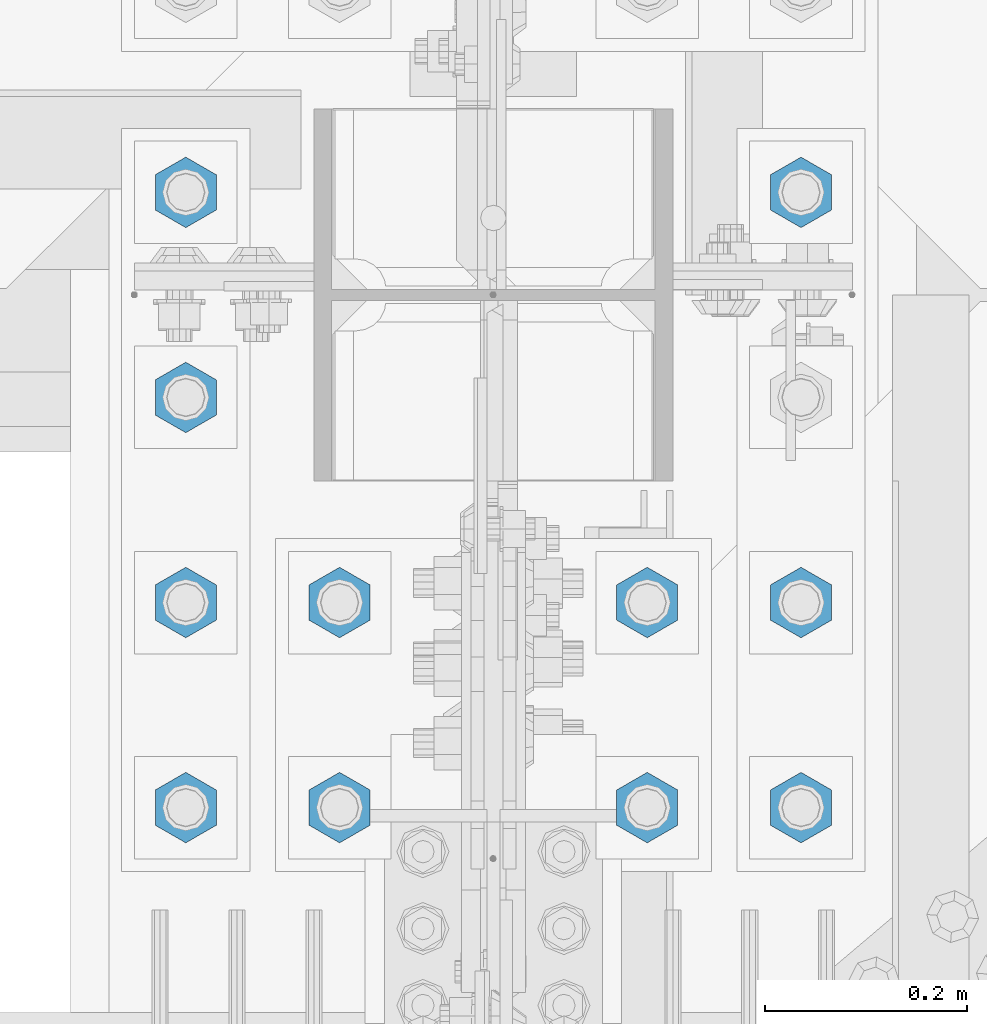
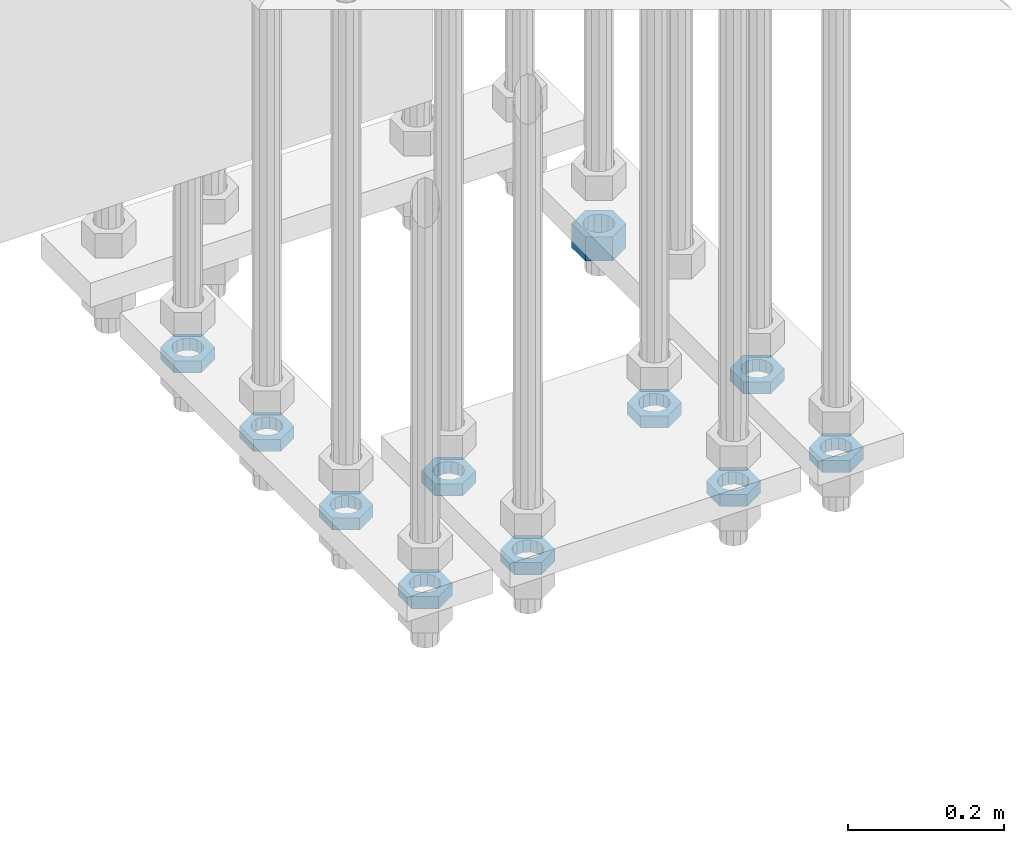
# One storey, part 2840 of 3843: 11 beams, 1 element without a shape of its own.
"""IFC2X3 building model written with IfcOpenShell, lengths in millimetres."""

from ifc_helpers import new_model, si_unit, frame, origin_with_axes, place, context, subcontext, project, spatial, faceted_brep, material, type_object, element, aggregate, save


model = new_model("IFC2X3")

# Units and contexts
model_context = context("Model", 3, precision=1e-05, world=origin_with_axes())
body_context = subcontext(model_context, "Body", "Model", "MODEL_VIEW")
ifc_project = project(units=[si_unit("LENGTHUNIT", "METRE", prefix="MILLI"), si_unit("AREAUNIT", "SQUARE_METRE"), si_unit("VOLUMEUNIT", "CUBIC_METRE"), si_unit("MASSUNIT", "GRAM", prefix="KILO"), si_unit("TIMEUNIT", "SECOND"), si_unit("PLANEANGLEUNIT", "RADIAN"), si_unit("SOLIDANGLEUNIT", "STERADIAN"), si_unit("THERMODYNAMICTEMPERATUREUNIT", "DEGREE_CELSIUS"), si_unit("LUMINOUSINTENSITYUNIT", "LUMEN")], contexts=[model_context])

# Site, building, storey
site_placement = place(None, origin_with_axes())
site = spatial("IfcSite", under=ifc_project, at=site_placement, CompositionType="ELEMENT")
building_placement = place(site_placement, origin_with_axes())
building = spatial("IfcBuilding", under=site, at=building_placement, Name="Undefined", CompositionType="ELEMENT")
storey_placement = place(building_placement, origin_with_axes())
storey = spatial("IfcBuildingStorey", under=building, at=storey_placement, Name="Undefined", CompositionType="ELEMENT", Elevation=0.0)

# Assembly, beams
assembly_placement = place(storey_placement, origin_with_axes())
assembly = element("IfcElementAssembly", 1, at=assembly_placement, inside=storey, Name="TEMPLATE", AssemblyPlace="NOTDEFINED", PredefinedType="RIGID_FRAME")
ifc_material = material(Name="STEEL/A572-50")
beam_type_1 = type_object("IfcBeamType", Name="1-1/2_HEAVY_HEX_NUT", PredefinedType="NOTDEFINED")
beam_1_placement = place(assembly_placement, frame((77317.6, 25717.5, 29203.6500015259), z_axis=(1.0, 0.0, 0.0), x_axis=(0.0, 0.0, -1.0)))
beam_1 = element("IfcBeam", 2, at=beam_1_placement, type_object=beam_type_1, material=ifc_material, Name="NUT", ObjectType="1-1/2_HEAVY_HEX_NUT", context=body_context, shape_type="Brep", body=[
    faceted_brep([(0.0, -34.9199981689453, 0.0), (0.0, -17.4599990844727, -30.25), (38.0999999999985, -17.4599990844727, -30.25), (38.0999999999985, -34.9199981689453, 0.0), (0.0, 17.4599990844727, -30.25), (38.0999999999985, 17.4599990844727, -30.25), (0.0, 34.9199981689453, 0.0), (38.0999999999985, 34.9199981689453, 0.0), (0.0, 17.4599990844727, 30.25), (38.0999999999985, 17.4599990844727, 30.25), (0.0, -17.4599990844727, 30.25), (38.0999999999985, -17.4599990844727, 30.25), (0.0, 0.0, 20.6399993896484), (0.0, 8.9553601105581, 18.5959968835959), (38.0999999999985, 8.9553601105581, 18.5959968835959), (38.0999999999985, 0.0, 20.6399993896484), (0.0, 16.1370013209525, 12.8688291298167), (38.0999999999985, 16.1370013209525, 12.8688291298167), (0.0, 20.1225115123816, 4.59283194104501), (38.0999999999985, 20.1225115123816, 4.59283194104501), (0.0, 20.1225115123816, -4.59283194104501), (38.0999999999985, 20.1225115123816, -4.59283194104501), (0.0, 16.1370013209525, -12.8688291298167), (38.0999999999985, 16.1370013209525, -12.8688291298167), (0.0, 8.9553601105581, -18.5959968835959), (38.0999999999985, 8.9553601105581, -18.5959968835959), (0.0, 0.0, -20.6399993896484), (38.0999999999985, 0.0, -20.6399993896484), (0.0, -8.9553601105581, -18.5959968835959), (38.0999999999985, -8.9553601105581, -18.5959968835959), (0.0, -16.1370013209525, -12.8688291298167), (38.0999999999985, -16.1370013209525, -12.8688291298167), (0.0, -20.1225115123816, -4.59283194104501), (38.0999999999985, -20.1225115123816, -4.59283194104501), (0.0, -20.1225115123816, 4.59283194104501), (38.0999999999985, -20.1225115123816, 4.59283194104501), (0.0, -16.1370013209525, 12.8688291298167), (38.0999999999985, -16.1370013209525, 12.8688291298167), (0.0, -8.9553601105581, 18.5959968835959), (38.0999999999985, -8.9553601105581, 18.5959968835959)], [[[0, 1, 2, 3]], [[1, 4, 5, 2]], [[4, 6, 7, 5]], [[6, 8, 9, 7]], [[8, 10, 11, 9]], [[10, 0, 3, 11]], [[12, 13, 14, 15]], [[13, 16, 17, 14]], [[16, 18, 19, 17]], [[18, 20, 21, 19]], [[20, 22, 23, 21]], [[22, 24, 25, 23]], [[24, 26, 27, 25]], [[26, 28, 29, 27]], [[28, 30, 31, 29]], [[30, 32, 33, 31]], [[32, 34, 35, 33]], [[34, 36, 37, 35]], [[36, 38, 39, 37]], [[38, 12, 15, 39]], [[5, 7, 9, 11, 3, 2], [17, 19, 21, 23, 25, 27, 29, 31, 33, 35, 37, 39, 15, 14]], [[10, 8, 6, 4, 1, 0], [38, 36, 34, 32, 30, 28, 26, 24, 22, 20, 18, 16, 13, 12]]]),
])
beam_type_2 = type_object("IfcBeamType", Name="1-1/2_HALF_NUT", PredefinedType="NOTDEFINED")
beam_2_placement = place(assembly_placement, frame((77317.6, 25311.1, 29222.7000015259), z_axis=(-1.0, 0.0, 0.0), x_axis=(0.0, 0.0, -1.0)))
beam_2 = element("IfcBeam", 3, at=beam_2_placement, type_object=beam_type_2, material=ifc_material, Name="NUT", ObjectType="1-1/2_HALF_NUT", context=body_context, shape_type="Brep", body=[
    faceted_brep([(0.0, -34.9199981689453, 0.0), (0.0, -17.4599990844727, -30.25), (19.0500000000029, -17.4599990844727, -30.25), (19.0500000000029, -34.9199981689453, 0.0), (0.0, 17.4599990844727, -30.25), (19.0500000000029, 17.4599990844727, -30.25), (0.0, 34.9199981689453, 0.0), (19.0500000000029, 34.9199981689453, 0.0), (0.0, 17.4599990844727, 30.25), (19.0500000000029, 17.4599990844727, 30.25), (0.0, -17.4599990844727, 30.25), (19.0500000000029, -17.4599990844727, 30.25), (0.0, 0.0, 20.6399993896484), (0.0, 8.9553601105581, 18.5959968835959), (19.0500000000029, 8.95536011056538, 18.5959968835959), (19.0500000000029, 0.0, 20.6399993896484), (0.0, 16.1370013209525, 12.8688291298167), (19.0500000000029, 16.1370013209489, 12.8688291298167), (0.0, 20.1225115123816, 4.59283194104501), (19.0500000000029, 20.1225115123852, 4.59283194104501), (0.0, 20.1225115123816, -4.59283194104501), (19.0500000000029, 20.1225115123852, -4.59283194104501), (0.0, 16.1370013209525, -12.8688291298167), (19.0500000000029, 16.1370013209489, -12.8688291298167), (0.0, 8.9553601105581, -18.5959968835959), (19.0500000000029, 8.95536011056538, -18.5959968835959), (0.0, 0.0, -20.6399993896484), (19.0500000000029, 0.0, -20.6399993896484), (0.0, -8.9553601105581, -18.5959968835959), (19.0500000000029, -8.95536011056538, -18.5959968835959), (0.0, -16.1370013209525, -12.8688291298167), (19.0500000000029, -16.1370013209489, -12.8688291298167), (0.0, -20.1225115123816, -4.59283194104501), (19.0500000000029, -20.1225115123852, -4.59283194104501), (0.0, -20.1225115123816, 4.59283194104501), (19.0500000000029, -20.1225115123852, 4.59283194104501), (0.0, -16.1370013209525, 12.8688291298167), (19.0500000000029, -16.1370013209489, 12.8688291298167), (0.0, -8.9553601105581, 18.5959968835959), (19.0500000000029, -8.95536011056538, 18.5959968835959)], [[[0, 1, 2, 3]], [[1, 4, 5, 2]], [[4, 6, 7, 5]], [[6, 8, 9, 7]], [[8, 10, 11, 9]], [[10, 0, 3, 11]], [[12, 13, 14, 15]], [[13, 16, 17, 14]], [[16, 18, 19, 17]], [[18, 20, 21, 19]], [[20, 22, 23, 21]], [[22, 24, 25, 23]], [[24, 26, 27, 25]], [[26, 28, 29, 27]], [[28, 30, 31, 29]], [[30, 32, 33, 31]], [[32, 34, 35, 33]], [[34, 36, 37, 35]], [[36, 38, 39, 37]], [[38, 12, 15, 39]], [[5, 7, 9, 11, 3, 2], [17, 19, 21, 23, 25, 27, 29, 31, 33, 35, 37, 39, 15, 14]], [[10, 8, 6, 4, 1, 0], [38, 36, 34, 32, 30, 28, 26, 24, 22, 20, 18, 16, 13, 12]]]),
])
beam_3_placement = place(assembly_placement, frame((77317.6, 25107.899974823, 29222.7), z_axis=(-1.0, 0.0, 0.0), x_axis=(0.0, 0.0, -1.0)))
beam_3 = element("IfcBeam", 4, at=beam_3_placement, type_object=beam_type_2, material=ifc_material, Name="NUT", ObjectType="1-1/2_HALF_NUT", context=body_context, shape_type="Brep", body=[
    faceted_brep([(0.0, -34.9199981689453, 0.0), (0.0, -17.4599990844727, -30.25), (19.0500000000029, -17.4599990844727, -30.25), (19.0500000000029, -34.9199981689453, 0.0), (0.0, 17.4599990844727, -30.25), (19.0500000000029, 17.4599990844727, -30.25), (0.0, 34.9199981689453, 0.0), (19.0500000000029, 34.9199981689453, 0.0), (0.0, 17.4599990844727, 30.25), (19.0500000000029, 17.4599990844727, 30.25), (0.0, -17.4599990844727, 30.25), (19.0500000000029, -17.4599990844727, 30.25), (0.0, 0.0, 20.6399993896484), (0.0, 8.9553601105581, 18.5959968835959), (19.0500000000029, 8.95536011056538, 18.5959968835959), (19.0500000000029, 0.0, 20.6399993896484), (0.0, 16.1370013209525, 12.8688291298167), (19.0500000000029, 16.1370013209489, 12.8688291298167), (0.0, 20.1225115123816, 4.59283194104501), (19.0500000000029, 20.1225115123852, 4.59283194104501), (0.0, 20.1225115123816, -4.59283194104501), (19.0500000000029, 20.1225115123852, -4.59283194104501), (0.0, 16.1370013209525, -12.8688291298167), (19.0500000000029, 16.1370013209489, -12.8688291298167), (0.0, 8.9553601105581, -18.5959968835959), (19.0500000000029, 8.95536011056538, -18.5959968835959), (0.0, 0.0, -20.6399993896484), (19.0500000000029, 0.0, -20.6399993896484), (0.0, -8.9553601105581, -18.5959968835959), (19.0500000000029, -8.95536011056538, -18.5959968835959), (0.0, -16.1370013209525, -12.8688291298167), (19.0500000000029, -16.1370013209489, -12.8688291298167), (0.0, -20.1225115123816, -4.59283194104501), (19.0500000000029, -20.1225115123852, -4.59283194104501), (0.0, -20.1225115123816, 4.59283194104501), (19.0500000000029, -20.1225115123852, 4.59283194104501), (0.0, -16.1370013209525, 12.8688291298167), (19.0500000000029, -16.1370013209489, 12.8688291298167), (0.0, -8.9553601105581, 18.5959968835959), (19.0500000000029, -8.95536011056538, 18.5959968835959)], [[[0, 1, 2, 3]], [[1, 4, 5, 2]], [[4, 6, 7, 5]], [[6, 8, 9, 7]], [[8, 10, 11, 9]], [[10, 0, 3, 11]], [[12, 13, 14, 15]], [[13, 16, 17, 14]], [[16, 18, 19, 17]], [[18, 20, 21, 19]], [[20, 22, 23, 21]], [[22, 24, 25, 23]], [[24, 26, 27, 25]], [[26, 28, 29, 27]], [[28, 30, 31, 29]], [[30, 32, 33, 31]], [[32, 34, 35, 33]], [[34, 36, 37, 35]], [[36, 38, 39, 37]], [[38, 12, 15, 39]], [[5, 7, 9, 11, 3, 2], [17, 19, 21, 23, 25, 27, 29, 31, 33, 35, 37, 39, 15, 14]], [[10, 8, 6, 4, 1, 0], [38, 36, 34, 32, 30, 28, 26, 24, 22, 20, 18, 16, 13, 12]]]),
])
beam_4_placement = place(assembly_placement, frame((77165.2, 25311.1, 29222.7000015259), z_axis=(-1.0, 0.0, 0.0), x_axis=(0.0, 0.0, -1.0)))
beam_4 = element("IfcBeam", 5, at=beam_4_placement, type_object=beam_type_2, material=ifc_material, Name="NUT", ObjectType="1-1/2_HALF_NUT", context=body_context, shape_type="Brep", body=[
    faceted_brep([(0.0, -34.9199981689453, 0.0), (0.0, -17.4599990844727, -30.25), (19.0500000000029, -17.4599990844727, -30.25), (19.0500000000029, -34.9199981689453, 0.0), (0.0, 17.4599990844727, -30.25), (19.0500000000029, 17.4599990844727, -30.25), (0.0, 34.9199981689453, 0.0), (19.0500000000029, 34.9199981689453, 0.0), (0.0, 17.4599990844727, 30.25), (19.0500000000029, 17.4599990844727, 30.25), (0.0, -17.4599990844727, 30.25), (19.0500000000029, -17.4599990844727, 30.25), (0.0, 0.0, 20.6399993896484), (0.0, 8.9553601105581, 18.5959968835959), (19.0500000000029, 8.95536011056538, 18.5959968835959), (19.0500000000029, 0.0, 20.6399993896484), (0.0, 16.1370013209525, 12.8688291298167), (19.0500000000029, 16.1370013209489, 12.8688291298167), (0.0, 20.1225115123816, 4.59283194104501), (19.0500000000029, 20.1225115123852, 4.59283194104501), (0.0, 20.1225115123816, -4.59283194104501), (19.0500000000029, 20.1225115123852, -4.59283194104501), (0.0, 16.1370013209525, -12.8688291298167), (19.0500000000029, 16.1370013209489, -12.8688291298167), (0.0, 8.9553601105581, -18.5959968835959), (19.0500000000029, 8.95536011056538, -18.5959968835959), (0.0, 0.0, -20.6399993896484), (19.0500000000029, 0.0, -20.6399993896484), (0.0, -8.9553601105581, -18.5959968835959), (19.0500000000029, -8.95536011056538, -18.5959968835959), (0.0, -16.1370013209525, -12.8688291298167), (19.0500000000029, -16.1370013209489, -12.8688291298167), (0.0, -20.1225115123816, -4.59283194104501), (19.0500000000029, -20.1225115123852, -4.59283194104501), (0.0, -20.1225115123816, 4.59283194104501), (19.0500000000029, -20.1225115123852, 4.59283194104501), (0.0, -16.1370013209525, 12.8688291298167), (19.0500000000029, -16.1370013209489, 12.8688291298167), (0.0, -8.9553601105581, 18.5959968835959), (19.0500000000029, -8.95536011056538, 18.5959968835959)], [[[0, 1, 2, 3]], [[1, 4, 5, 2]], [[4, 6, 7, 5]], [[6, 8, 9, 7]], [[8, 10, 11, 9]], [[10, 0, 3, 11]], [[12, 13, 14, 15]], [[13, 16, 17, 14]], [[16, 18, 19, 17]], [[18, 20, 21, 19]], [[20, 22, 23, 21]], [[22, 24, 25, 23]], [[24, 26, 27, 25]], [[26, 28, 29, 27]], [[28, 30, 31, 29]], [[30, 32, 33, 31]], [[32, 34, 35, 33]], [[34, 36, 37, 35]], [[36, 38, 39, 37]], [[38, 12, 15, 39]], [[5, 7, 9, 11, 3, 2], [17, 19, 21, 23, 25, 27, 29, 31, 33, 35, 37, 39, 15, 14]], [[10, 8, 6, 4, 1, 0], [38, 36, 34, 32, 30, 28, 26, 24, 22, 20, 18, 16, 13, 12]]]),
])
beam_5_placement = place(assembly_placement, frame((77165.2, 25107.9, 29222.7000015259), z_axis=(-1.0, 0.0, 0.0), x_axis=(0.0, 0.0, -1.0)))
beam_5 = element("IfcBeam", 6, at=beam_5_placement, type_object=beam_type_2, material=ifc_material, Name="NUT", ObjectType="1-1/2_HALF_NUT", context=body_context, shape_type="Brep", body=[
    faceted_brep([(0.0, -34.9199981689453, 0.0), (0.0, -17.4599990844727, -30.25), (19.0500000000029, -17.4599990844727, -30.25), (19.0500000000029, -34.9199981689453, 0.0), (0.0, 17.4599990844727, -30.25), (19.0500000000029, 17.4599990844727, -30.25), (0.0, 34.9199981689453, 0.0), (19.0500000000029, 34.9199981689453, 0.0), (0.0, 17.4599990844727, 30.25), (19.0500000000029, 17.4599990844727, 30.25), (0.0, -17.4599990844727, 30.25), (19.0500000000029, -17.4599990844727, 30.25), (0.0, 0.0, 20.6399993896484), (0.0, 8.9553601105581, 18.5959968835959), (19.0500000000029, 8.95536011056538, 18.5959968835959), (19.0500000000029, 0.0, 20.6399993896484), (0.0, 16.1370013209525, 12.8688291298167), (19.0500000000029, 16.1370013209489, 12.8688291298167), (0.0, 20.1225115123816, 4.59283194104501), (19.0500000000029, 20.1225115123852, 4.59283194104501), (0.0, 20.1225115123816, -4.59283194104501), (19.0500000000029, 20.1225115123852, -4.59283194104501), (0.0, 16.1370013209525, -12.8688291298167), (19.0500000000029, 16.1370013209489, -12.8688291298167), (0.0, 8.9553601105581, -18.5959968835959), (19.0500000000029, 8.95536011056538, -18.5959968835959), (0.0, 0.0, -20.6399993896484), (19.0500000000029, 0.0, -20.6399993896484), (0.0, -8.9553601105581, -18.5959968835959), (19.0500000000029, -8.95536011056538, -18.5959968835959), (0.0, -16.1370013209525, -12.8688291298167), (19.0500000000029, -16.1370013209489, -12.8688291298167), (0.0, -20.1225115123816, -4.59283194104501), (19.0500000000029, -20.1225115123852, -4.59283194104501), (0.0, -20.1225115123816, 4.59283194104501), (19.0500000000029, -20.1225115123852, 4.59283194104501), (0.0, -16.1370013209525, 12.8688291298167), (19.0500000000029, -16.1370013209489, 12.8688291298167), (0.0, -8.9553601105581, 18.5959968835959), (19.0500000000029, -8.95536011056538, 18.5959968835959)], [[[0, 1, 2, 3]], [[1, 4, 5, 2]], [[4, 6, 7, 5]], [[6, 8, 9, 7]], [[8, 10, 11, 9]], [[10, 0, 3, 11]], [[12, 13, 14, 15]], [[13, 16, 17, 14]], [[16, 18, 19, 17]], [[18, 20, 21, 19]], [[20, 22, 23, 21]], [[22, 24, 25, 23]], [[24, 26, 27, 25]], [[26, 28, 29, 27]], [[28, 30, 31, 29]], [[30, 32, 33, 31]], [[32, 34, 35, 33]], [[34, 36, 37, 35]], [[36, 38, 39, 37]], [[38, 12, 15, 39]], [[5, 7, 9, 11, 3, 2], [17, 19, 21, 23, 25, 27, 29, 31, 33, 35, 37, 39, 15, 14]], [[10, 8, 6, 4, 1, 0], [38, 36, 34, 32, 30, 28, 26, 24, 22, 20, 18, 16, 13, 12]]]),
])
beam_6_placement = place(assembly_placement, frame((76860.4, 25311.1, 29222.7000015259), z_axis=(-1.0, 0.0, 0.0), x_axis=(0.0, 0.0, -1.0)))
beam_6 = element("IfcBeam", 7, at=beam_6_placement, type_object=beam_type_2, material=ifc_material, Name="NUT", ObjectType="1-1/2_HALF_NUT", context=body_context, shape_type="Brep", body=[
    faceted_brep([(0.0, -34.9199981689453, 0.0), (0.0, -17.4599990844727, -30.25), (19.0500000000029, -17.4599990844727, -30.25), (19.0500000000029, -34.9199981689453, 0.0), (0.0, 17.4599990844727, -30.25), (19.0500000000029, 17.4599990844727, -30.25), (0.0, 34.9199981689453, 0.0), (19.0500000000029, 34.9199981689453, 0.0), (0.0, 17.4599990844727, 30.25), (19.0500000000029, 17.4599990844727, 30.25), (0.0, -17.4599990844727, 30.25), (19.0500000000029, -17.4599990844727, 30.25), (0.0, 0.0, 20.6399993896484), (0.0, 8.9553601105581, 18.5959968835959), (19.0500000000029, 8.95536011056538, 18.5959968835959), (19.0500000000029, 0.0, 20.6399993896484), (0.0, 16.1370013209525, 12.8688291298167), (19.0500000000029, 16.1370013209489, 12.8688291298167), (0.0, 20.1225115123816, 4.59283194104501), (19.0500000000029, 20.1225115123852, 4.59283194104501), (0.0, 20.1225115123816, -4.59283194104501), (19.0500000000029, 20.1225115123852, -4.59283194104501), (0.0, 16.1370013209525, -12.8688291298167), (19.0500000000029, 16.1370013209489, -12.8688291298167), (0.0, 8.9553601105581, -18.5959968835959), (19.0500000000029, 8.95536011056538, -18.5959968835959), (0.0, 0.0, -20.6399993896484), (19.0500000000029, 0.0, -20.6399993896484), (0.0, -8.9553601105581, -18.5959968835959), (19.0500000000029, -8.95536011056538, -18.5959968835959), (0.0, -16.1370013209525, -12.8688291298167), (19.0500000000029, -16.1370013209489, -12.8688291298167), (0.0, -20.1225115123816, -4.59283194104501), (19.0500000000029, -20.1225115123852, -4.59283194104501), (0.0, -20.1225115123816, 4.59283194104501), (19.0500000000029, -20.1225115123852, 4.59283194104501), (0.0, -16.1370013209525, 12.8688291298167), (19.0500000000029, -16.1370013209489, 12.8688291298167), (0.0, -8.9553601105581, 18.5959968835959), (19.0500000000029, -8.95536011056538, 18.5959968835959)], [[[0, 1, 2, 3]], [[1, 4, 5, 2]], [[4, 6, 7, 5]], [[6, 8, 9, 7]], [[8, 10, 11, 9]], [[10, 0, 3, 11]], [[12, 13, 14, 15]], [[13, 16, 17, 14]], [[16, 18, 19, 17]], [[18, 20, 21, 19]], [[20, 22, 23, 21]], [[22, 24, 25, 23]], [[24, 26, 27, 25]], [[26, 28, 29, 27]], [[28, 30, 31, 29]], [[30, 32, 33, 31]], [[32, 34, 35, 33]], [[34, 36, 37, 35]], [[36, 38, 39, 37]], [[38, 12, 15, 39]], [[5, 7, 9, 11, 3, 2], [17, 19, 21, 23, 25, 27, 29, 31, 33, 35, 37, 39, 15, 14]], [[10, 8, 6, 4, 1, 0], [38, 36, 34, 32, 30, 28, 26, 24, 22, 20, 18, 16, 13, 12]]]),
])
beam_7_placement = place(assembly_placement, frame((76860.4, 25107.9, 29222.7000015259), z_axis=(-1.0, 0.0, 0.0), x_axis=(0.0, 0.0, -1.0)))
beam_7 = element("IfcBeam", 8, at=beam_7_placement, type_object=beam_type_2, material=ifc_material, Name="NUT", ObjectType="1-1/2_HALF_NUT", context=body_context, shape_type="Brep", body=[
    faceted_brep([(0.0, -34.9199981689453, 0.0), (0.0, -17.4599990844727, -30.25), (19.0500000000029, -17.4599990844727, -30.25), (19.0500000000029, -34.9199981689453, 0.0), (0.0, 17.4599990844727, -30.25), (19.0500000000029, 17.4599990844727, -30.25), (0.0, 34.9199981689453, 0.0), (19.0500000000029, 34.9199981689453, 0.0), (0.0, 17.4599990844727, 30.25), (19.0500000000029, 17.4599990844727, 30.25), (0.0, -17.4599990844727, 30.25), (19.0500000000029, -17.4599990844727, 30.25), (0.0, 0.0, 20.6399993896484), (0.0, 8.9553601105581, 18.5959968835959), (19.0500000000029, 8.95536011056538, 18.5959968835959), (19.0500000000029, 0.0, 20.6399993896484), (0.0, 16.1370013209525, 12.8688291298167), (19.0500000000029, 16.1370013209489, 12.8688291298167), (0.0, 20.1225115123816, 4.59283194104501), (19.0500000000029, 20.1225115123852, 4.59283194104501), (0.0, 20.1225115123816, -4.59283194104501), (19.0500000000029, 20.1225115123852, -4.59283194104501), (0.0, 16.1370013209525, -12.8688291298167), (19.0500000000029, 16.1370013209489, -12.8688291298167), (0.0, 8.9553601105581, -18.5959968835959), (19.0500000000029, 8.95536011056538, -18.5959968835959), (0.0, 0.0, -20.6399993896484), (19.0500000000029, 0.0, -20.6399993896484), (0.0, -8.9553601105581, -18.5959968835959), (19.0500000000029, -8.95536011056538, -18.5959968835959), (0.0, -16.1370013209525, -12.8688291298167), (19.0500000000029, -16.1370013209489, -12.8688291298167), (0.0, -20.1225115123816, -4.59283194104501), (19.0500000000029, -20.1225115123852, -4.59283194104501), (0.0, -20.1225115123816, 4.59283194104501), (19.0500000000029, -20.1225115123852, 4.59283194104501), (0.0, -16.1370013209525, 12.8688291298167), (19.0500000000029, -16.1370013209489, 12.8688291298167), (0.0, -8.9553601105581, 18.5959968835959), (19.0500000000029, -8.95536011056538, 18.5959968835959)], [[[0, 1, 2, 3]], [[1, 4, 5, 2]], [[4, 6, 7, 5]], [[6, 8, 9, 7]], [[8, 10, 11, 9]], [[10, 0, 3, 11]], [[12, 13, 14, 15]], [[13, 16, 17, 14]], [[16, 18, 19, 17]], [[18, 20, 21, 19]], [[20, 22, 23, 21]], [[22, 24, 25, 23]], [[24, 26, 27, 25]], [[26, 28, 29, 27]], [[28, 30, 31, 29]], [[30, 32, 33, 31]], [[32, 34, 35, 33]], [[34, 36, 37, 35]], [[36, 38, 39, 37]], [[38, 12, 15, 39]], [[5, 7, 9, 11, 3, 2], [17, 19, 21, 23, 25, 27, 29, 31, 33, 35, 37, 39, 15, 14]], [[10, 8, 6, 4, 1, 0], [38, 36, 34, 32, 30, 28, 26, 24, 22, 20, 18, 16, 13, 12]]]),
])
beam_8_placement = place(assembly_placement, frame((76708.0, 25717.5, 29222.7000015259), z_axis=(1.0, 0.0, 0.0), x_axis=(0.0, 0.0, -1.0)))
beam_8 = element("IfcBeam", 9, at=beam_8_placement, type_object=beam_type_2, material=ifc_material, Name="NUT", ObjectType="1-1/2_HALF_NUT", context=body_context, shape_type="Brep", body=[
    faceted_brep([(0.0, -34.9199981689453, 0.0), (0.0, -17.4599990844727, -30.25), (19.0500000000029, -17.4599990844727, -30.25), (19.0500000000029, -34.9199981689453, 0.0), (0.0, 17.4599990844727, -30.25), (19.0500000000029, 17.4599990844727, -30.25), (0.0, 34.9199981689453, 0.0), (19.0500000000029, 34.9199981689453, 0.0), (0.0, 17.4599990844727, 30.25), (19.0500000000029, 17.4599990844727, 30.25), (0.0, -17.4599990844727, 30.25), (19.0500000000029, -17.4599990844727, 30.25), (0.0, 0.0, 20.6399993896484), (0.0, 8.9553601105581, 18.5959968835959), (19.0500000000029, 8.95536011056538, 18.5959968835959), (19.0500000000029, 0.0, 20.6399993896484), (0.0, 16.1370013209525, 12.8688291298167), (19.0500000000029, 16.1370013209489, 12.8688291298167), (0.0, 20.1225115123816, 4.59283194104501), (19.0500000000029, 20.1225115123852, 4.59283194104501), (0.0, 20.1225115123816, -4.59283194104501), (19.0500000000029, 20.1225115123852, -4.59283194104501), (0.0, 16.1370013209525, -12.8688291298167), (19.0500000000029, 16.1370013209489, -12.8688291298167), (0.0, 8.9553601105581, -18.5959968835959), (19.0500000000029, 8.95536011056538, -18.5959968835959), (0.0, 0.0, -20.6399993896484), (19.0500000000029, 0.0, -20.6399993896484), (0.0, -8.9553601105581, -18.5959968835959), (19.0500000000029, -8.95536011056538, -18.5959968835959), (0.0, -16.1370013209525, -12.8688291298167), (19.0500000000029, -16.1370013209489, -12.8688291298167), (0.0, -20.1225115123816, -4.59283194104501), (19.0500000000029, -20.1225115123852, -4.59283194104501), (0.0, -20.1225115123816, 4.59283194104501), (19.0500000000029, -20.1225115123852, 4.59283194104501), (0.0, -16.1370013209525, 12.8688291298167), (19.0500000000029, -16.1370013209489, 12.8688291298167), (0.0, -8.9553601105581, 18.5959968835959), (19.0500000000029, -8.95536011056538, 18.5959968835959)], [[[0, 1, 2, 3]], [[1, 4, 5, 2]], [[4, 6, 7, 5]], [[6, 8, 9, 7]], [[8, 10, 11, 9]], [[10, 0, 3, 11]], [[12, 13, 14, 15]], [[13, 16, 17, 14]], [[16, 18, 19, 17]], [[18, 20, 21, 19]], [[20, 22, 23, 21]], [[22, 24, 25, 23]], [[24, 26, 27, 25]], [[26, 28, 29, 27]], [[28, 30, 31, 29]], [[30, 32, 33, 31]], [[32, 34, 35, 33]], [[34, 36, 37, 35]], [[36, 38, 39, 37]], [[38, 12, 15, 39]], [[5, 7, 9, 11, 3, 2], [17, 19, 21, 23, 25, 27, 29, 31, 33, 35, 37, 39, 15, 14]], [[10, 8, 6, 4, 1, 0], [38, 36, 34, 32, 30, 28, 26, 24, 22, 20, 18, 16, 13, 12]]]),
])
beam_9_placement = place(assembly_placement, frame((76708.0, 25514.3, 29222.7000015259), z_axis=(1.0, 0.0, 0.0), x_axis=(0.0, 0.0, -1.0)))
beam_9 = element("IfcBeam", 10, at=beam_9_placement, type_object=beam_type_2, material=ifc_material, Name="NUT", ObjectType="1-1/2_HALF_NUT", context=body_context, shape_type="Brep", body=[
    faceted_brep([(0.0, -34.9199981689453, 0.0), (0.0, -17.4599990844727, -30.25), (19.0500000000029, -17.4599990844727, -30.25), (19.0500000000029, -34.9199981689453, 0.0), (0.0, 17.4599990844727, -30.25), (19.0500000000029, 17.4599990844727, -30.25), (0.0, 34.9199981689453, 0.0), (19.0500000000029, 34.9199981689453, 0.0), (0.0, 17.4599990844727, 30.25), (19.0500000000029, 17.4599990844727, 30.25), (0.0, -17.4599990844727, 30.25), (19.0500000000029, -17.4599990844727, 30.25), (0.0, 0.0, 20.6399993896484), (0.0, 8.9553601105581, 18.5959968835959), (19.0500000000029, 8.95536011056538, 18.5959968835959), (19.0500000000029, 0.0, 20.6399993896484), (0.0, 16.1370013209525, 12.8688291298167), (19.0500000000029, 16.1370013209489, 12.8688291298167), (0.0, 20.1225115123816, 4.59283194104501), (19.0500000000029, 20.1225115123852, 4.59283194104501), (0.0, 20.1225115123816, -4.59283194104501), (19.0500000000029, 20.1225115123852, -4.59283194104501), (0.0, 16.1370013209525, -12.8688291298167), (19.0500000000029, 16.1370013209489, -12.8688291298167), (0.0, 8.9553601105581, -18.5959968835959), (19.0500000000029, 8.95536011056538, -18.5959968835959), (0.0, 0.0, -20.6399993896484), (19.0500000000029, 0.0, -20.6399993896484), (0.0, -8.9553601105581, -18.5959968835959), (19.0500000000029, -8.95536011056538, -18.5959968835959), (0.0, -16.1370013209525, -12.8688291298167), (19.0500000000029, -16.1370013209489, -12.8688291298167), (0.0, -20.1225115123816, -4.59283194104501), (19.0500000000029, -20.1225115123852, -4.59283194104501), (0.0, -20.1225115123816, 4.59283194104501), (19.0500000000029, -20.1225115123852, 4.59283194104501), (0.0, -16.1370013209525, 12.8688291298167), (19.0500000000029, -16.1370013209489, 12.8688291298167), (0.0, -8.9553601105581, 18.5959968835959), (19.0500000000029, -8.95536011056538, 18.5959968835959)], [[[0, 1, 2, 3]], [[1, 4, 5, 2]], [[4, 6, 7, 5]], [[6, 8, 9, 7]], [[8, 10, 11, 9]], [[10, 0, 3, 11]], [[12, 13, 14, 15]], [[13, 16, 17, 14]], [[16, 18, 19, 17]], [[18, 20, 21, 19]], [[20, 22, 23, 21]], [[22, 24, 25, 23]], [[24, 26, 27, 25]], [[26, 28, 29, 27]], [[28, 30, 31, 29]], [[30, 32, 33, 31]], [[32, 34, 35, 33]], [[34, 36, 37, 35]], [[36, 38, 39, 37]], [[38, 12, 15, 39]], [[5, 7, 9, 11, 3, 2], [17, 19, 21, 23, 25, 27, 29, 31, 33, 35, 37, 39, 15, 14]], [[10, 8, 6, 4, 1, 0], [38, 36, 34, 32, 30, 28, 26, 24, 22, 20, 18, 16, 13, 12]]]),
])
beam_10_placement = place(assembly_placement, frame((76708.0, 25311.1, 29222.7000015259), z_axis=(-1.0, 0.0, 0.0), x_axis=(0.0, 0.0, -1.0)))
beam_10 = element("IfcBeam", 11, at=beam_10_placement, type_object=beam_type_2, material=ifc_material, Name="NUT", ObjectType="1-1/2_HALF_NUT", context=body_context, shape_type="Brep", body=[
    faceted_brep([(0.0, -34.9199981689453, 0.0), (0.0, -17.4599990844727, -30.25), (19.0500000000029, -17.4599990844727, -30.25), (19.0500000000029, -34.9199981689453, 0.0), (0.0, 17.4599990844727, -30.25), (19.0500000000029, 17.4599990844727, -30.25), (0.0, 34.9199981689453, 0.0), (19.0500000000029, 34.9199981689453, 0.0), (0.0, 17.4599990844727, 30.25), (19.0500000000029, 17.4599990844727, 30.25), (0.0, -17.4599990844727, 30.25), (19.0500000000029, -17.4599990844727, 30.25), (0.0, 0.0, 20.6399993896484), (0.0, 8.9553601105581, 18.5959968835959), (19.0500000000029, 8.95536011056538, 18.5959968835959), (19.0500000000029, 0.0, 20.6399993896484), (0.0, 16.1370013209525, 12.8688291298167), (19.0500000000029, 16.1370013209489, 12.8688291298167), (0.0, 20.1225115123816, 4.59283194104501), (19.0500000000029, 20.1225115123852, 4.59283194104501), (0.0, 20.1225115123816, -4.59283194104501), (19.0500000000029, 20.1225115123852, -4.59283194104501), (0.0, 16.1370013209525, -12.8688291298167), (19.0500000000029, 16.1370013209489, -12.8688291298167), (0.0, 8.9553601105581, -18.5959968835959), (19.0500000000029, 8.95536011056538, -18.5959968835959), (0.0, 0.0, -20.6399993896484), (19.0500000000029, 0.0, -20.6399993896484), (0.0, -8.9553601105581, -18.5959968835959), (19.0500000000029, -8.95536011056538, -18.5959968835959), (0.0, -16.1370013209525, -12.8688291298167), (19.0500000000029, -16.1370013209489, -12.8688291298167), (0.0, -20.1225115123816, -4.59283194104501), (19.0500000000029, -20.1225115123852, -4.59283194104501), (0.0, -20.1225115123816, 4.59283194104501), (19.0500000000029, -20.1225115123852, 4.59283194104501), (0.0, -16.1370013209525, 12.8688291298167), (19.0500000000029, -16.1370013209489, 12.8688291298167), (0.0, -8.9553601105581, 18.5959968835959), (19.0500000000029, -8.95536011056538, 18.5959968835959)], [[[0, 1, 2, 3]], [[1, 4, 5, 2]], [[4, 6, 7, 5]], [[6, 8, 9, 7]], [[8, 10, 11, 9]], [[10, 0, 3, 11]], [[12, 13, 14, 15]], [[13, 16, 17, 14]], [[16, 18, 19, 17]], [[18, 20, 21, 19]], [[20, 22, 23, 21]], [[22, 24, 25, 23]], [[24, 26, 27, 25]], [[26, 28, 29, 27]], [[28, 30, 31, 29]], [[30, 32, 33, 31]], [[32, 34, 35, 33]], [[34, 36, 37, 35]], [[36, 38, 39, 37]], [[38, 12, 15, 39]], [[5, 7, 9, 11, 3, 2], [17, 19, 21, 23, 25, 27, 29, 31, 33, 35, 37, 39, 15, 14]], [[10, 8, 6, 4, 1, 0], [38, 36, 34, 32, 30, 28, 26, 24, 22, 20, 18, 16, 13, 12]]]),
])
beam_11_placement = place(assembly_placement, frame((76708.0, 25107.899974823, 29222.7), z_axis=(-1.0, 0.0, 0.0), x_axis=(0.0, 0.0, -1.0)))
beam_11 = element("IfcBeam", 12, at=beam_11_placement, type_object=beam_type_2, material=ifc_material, Name="NUT", ObjectType="1-1/2_HALF_NUT", context=body_context, shape_type="Brep", body=[
    faceted_brep([(0.0, -34.9199981689453, 0.0), (0.0, -17.4599990844727, -30.25), (19.0500000000029, -17.4599990844727, -30.25), (19.0500000000029, -34.9199981689453, 0.0), (0.0, 17.4599990844727, -30.25), (19.0500000000029, 17.4599990844727, -30.25), (0.0, 34.9199981689453, 0.0), (19.0500000000029, 34.9199981689453, 0.0), (0.0, 17.4599990844727, 30.25), (19.0500000000029, 17.4599990844727, 30.25), (0.0, -17.4599990844727, 30.25), (19.0500000000029, -17.4599990844727, 30.25), (0.0, 0.0, 20.6399993896484), (0.0, 8.9553601105581, 18.5959968835959), (19.0500000000029, 8.95536011056538, 18.5959968835959), (19.0500000000029, 0.0, 20.6399993896484), (0.0, 16.1370013209525, 12.8688291298167), (19.0500000000029, 16.1370013209489, 12.8688291298167), (0.0, 20.1225115123816, 4.59283194104501), (19.0500000000029, 20.1225115123852, 4.59283194104501), (0.0, 20.1225115123816, -4.59283194104501), (19.0500000000029, 20.1225115123852, -4.59283194104501), (0.0, 16.1370013209525, -12.8688291298167), (19.0500000000029, 16.1370013209489, -12.8688291298167), (0.0, 8.9553601105581, -18.5959968835959), (19.0500000000029, 8.95536011056538, -18.5959968835959), (0.0, 0.0, -20.6399993896484), (19.0500000000029, 0.0, -20.6399993896484), (0.0, -8.9553601105581, -18.5959968835959), (19.0500000000029, -8.95536011056538, -18.5959968835959), (0.0, -16.1370013209525, -12.8688291298167), (19.0500000000029, -16.1370013209489, -12.8688291298167), (0.0, -20.1225115123816, -4.59283194104501), (19.0500000000029, -20.1225115123852, -4.59283194104501), (0.0, -20.1225115123816, 4.59283194104501), (19.0500000000029, -20.1225115123852, 4.59283194104501), (0.0, -16.1370013209525, 12.8688291298167), (19.0500000000029, -16.1370013209489, 12.8688291298167), (0.0, -8.9553601105581, 18.5959968835959), (19.0500000000029, -8.95536011056538, 18.5959968835959)], [[[0, 1, 2, 3]], [[1, 4, 5, 2]], [[4, 6, 7, 5]], [[6, 8, 9, 7]], [[8, 10, 11, 9]], [[10, 0, 3, 11]], [[12, 13, 14, 15]], [[13, 16, 17, 14]], [[16, 18, 19, 17]], [[18, 20, 21, 19]], [[20, 22, 23, 21]], [[22, 24, 25, 23]], [[24, 26, 27, 25]], [[26, 28, 29, 27]], [[28, 30, 31, 29]], [[30, 32, 33, 31]], [[32, 34, 35, 33]], [[34, 36, 37, 35]], [[36, 38, 39, 37]], [[38, 12, 15, 39]], [[5, 7, 9, 11, 3, 2], [17, 19, 21, 23, 25, 27, 29, 31, 33, 35, 37, 39, 15, 14]], [[10, 8, 6, 4, 1, 0], [38, 36, 34, 32, 30, 28, 26, 24, 22, 20, 18, 16, 13, 12]]]),
])
aggregate(assembly, [beam_2, beam_3, beam_4, beam_5, beam_6, beam_7, beam_8, beam_9, beam_10, beam_11, beam_1])

save(model, "model.ifc")
